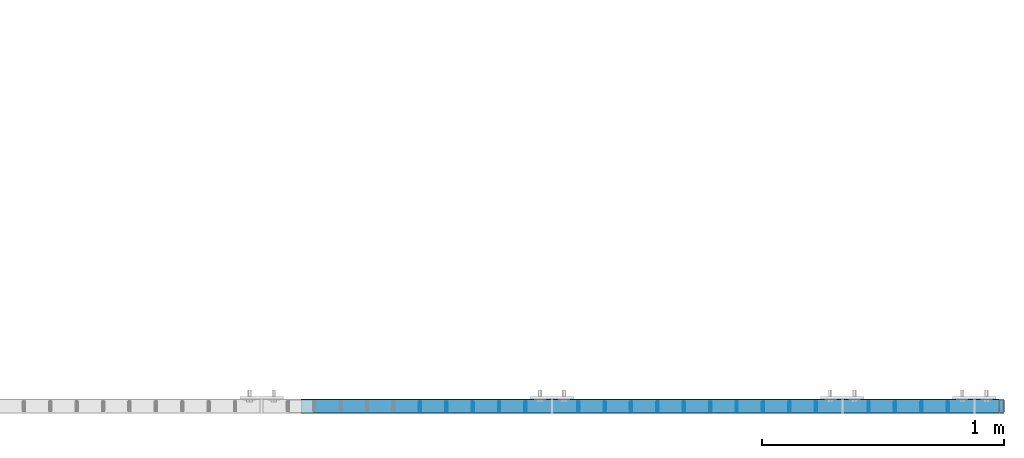
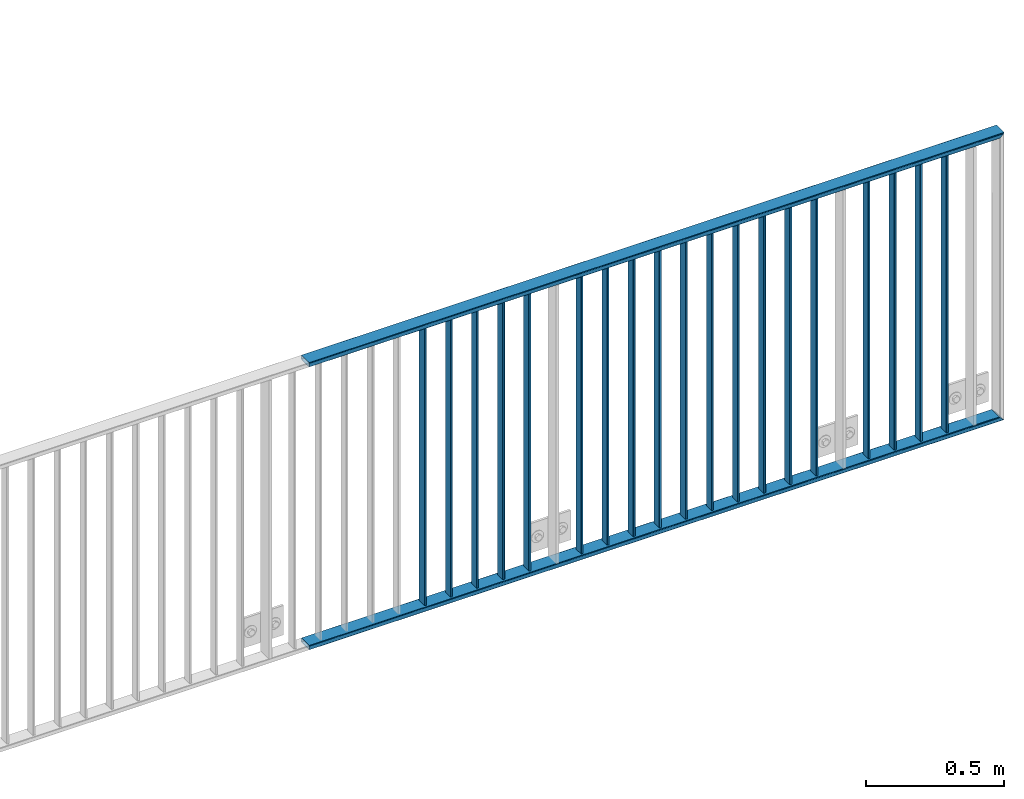
# One storey, part 31 of 156: 21 beams, 1 element without a shape of its own.
"""IFC2X3 building model written with IfcOpenShell, lengths in millimetres."""

from ifc_helpers import new_model, si_unit, frame, origin_with_axes, origin_2d_with_axis, place, context, subcontext, project, spatial, hollow_rectangle, extrude, clip, halfspace, material, type_object, element, aggregate, save


model = new_model("IFC2X3")

# Units and contexts
model_context = context("Model", 3, precision=1e-05, world=origin_with_axes())
body_context = subcontext(model_context, "Body", "Model", "MODEL_VIEW")
ifc_project = project(units=[si_unit("LENGTHUNIT", "METRE", prefix="MILLI"), si_unit("AREAUNIT", "SQUARE_METRE"), si_unit("VOLUMEUNIT", "CUBIC_METRE"), si_unit("MASSUNIT", "GRAM", prefix="KILO"), si_unit("TIMEUNIT", "SECOND"), si_unit("PLANEANGLEUNIT", "RADIAN"), si_unit("SOLIDANGLEUNIT", "STERADIAN"), si_unit("THERMODYNAMICTEMPERATUREUNIT", "DEGREE_CELSIUS"), si_unit("LUMINOUSINTENSITYUNIT", "LUMEN")], contexts=[model_context])

# Site, building, storey
site_placement = place(None, origin_with_axes())
site = spatial("IfcSite", under=ifc_project, at=site_placement, CompositionType="ELEMENT")
building_placement = place(site_placement, origin_with_axes())
building = spatial("IfcBuilding", under=site, at=building_placement, Name="Undefined", CompositionType="ELEMENT")
storey_placement = place(building_placement, origin_with_axes())
storey = spatial("IfcBuildingStorey", under=building, at=storey_placement, Name="Undefined", CompositionType="ELEMENT", Elevation=0.0)

# Assembly, beams
assembly_placement = place(storey_placement, origin_with_axes())
assembly = element("IfcElementAssembly", 1, at=assembly_placement, inside=storey, AssemblyPlace="NOTDEFINED", PredefinedType="RIGID_FRAME")
ifc_material = material(Name="STEEL/S235JR")
beam_type_1 = type_object("IfcBeamType", Name="K60/20/2", PredefinedType="NOTDEFINED")
beam_1_placement = place(assembly_placement, frame((46763.0399999997, 8480.00209045412, 2740.0), z_axis=(0.0, 1.0, 0.0), x_axis=(1.0, 0.0, 0.0)))
beam_1 = element("IfcBeam", 2, at=beam_1_placement, type_object=beam_type_1, material=ifc_material, ObjectType="K60/20/2", context=body_context, shape_type="Clipping", body=[
    clip(extrude(hollow_rectangle(XDim=20.0, YDim=60.0, WallThickness=2.0, InnerFilletRadius=2.0, OuterFilletRadius=4.0, at=origin_2d_with_axis()), frame((2905.05999999928, 0.0, 0.0), z_axis=(-1.0, 0.0, 0.0), x_axis=(0.0, -1.0, 0.0)), (0.0, 0.0, 1.0), 2905.06), halfspace(frame((2904.95999999928, 10.0, 7.25158861314412e-06), z_axis=(-0.707106781186548, 0.707106781186548, 0.0), x_axis=(0.0, 0.0, 1.0)), True)),
])
beam_2_placement = place(assembly_placement, frame((46763.0399999997, 8479.98209043043, 3990.0), z_axis=(0.0, 1.0, 0.0), x_axis=(1.0, 0.0, 0.0)))
beam_2 = element("IfcBeam", 3, at=beam_2_placement, type_object=beam_type_1, material=ifc_material, ObjectType="K60/20/2", context=body_context, shape_type="Clipping", body=[
    clip(extrude(hollow_rectangle(XDim=20.0, YDim=60.0, WallThickness=2.0, InnerFilletRadius=2.0, OuterFilletRadius=4.0, at=origin_2d_with_axis()), frame((2905.05999999928, 0.0, 0.0), z_axis=(-1.0, 0.0, 0.0), x_axis=(0.0, -1.0, 0.0)), (0.0, 0.0, 1.0), 2905.06), halfspace(frame((2884.95999999927, 10.0, 0.0200072752795677), z_axis=(-0.707106781186548, -0.707106781186548, 0.0), x_axis=(0.0, 0.0, 1.0)), True)),
])
beam_type_2 = type_object("IfcBeamType", Name="K40/10/1.5", PredefinedType="NOTDEFINED")
beam_3_placement = place(assembly_placement, frame((49436.359999999, 8480.00209765299, 3980.00000000003), z_axis=(0.0, 1.0, 0.0), x_axis=(0.0, 0.0, -1.0)))
beam_3 = element("IfcBeam", 4, at=beam_3_placement, type_object=beam_type_2, material=ifc_material, ObjectType="K40/10/1.5", context=body_context, shape_type="Clipping", body=[
    clip(extrude(hollow_rectangle(XDim=10.0, YDim=40.0, WallThickness=1.5, InnerFilletRadius=1.5, OuterFilletRadius=3.0, at=origin_2d_with_axis()), frame((1230.0, 0.0, 0.0), z_axis=(-1.0, 0.0, 0.0), x_axis=(0.0, -1.0, 0.0)), (0.0, 0.0, 1.0), 1230.0), halfspace(frame((-6.99999999997453, -4.34248751950508, 47.3810900558092), z_axis=(-1.0, 0.0, 0.0), x_axis=(0.0, 0.7683548141934, -0.640024124159258)), False)),
])
beam_4_placement = place(assembly_placement, frame((49327.269999999, 8480.00209765299, 3980.00000000003), z_axis=(0.0, 1.0, 0.0), x_axis=(0.0, 0.0, -1.0)))
beam_4 = element("IfcBeam", 5, at=beam_4_placement, type_object=beam_type_2, material=ifc_material, ObjectType="K40/10/1.5", context=body_context, shape_type="Clipping", body=[
    clip(extrude(hollow_rectangle(XDim=10.0, YDim=40.0, WallThickness=1.5, InnerFilletRadius=1.5, OuterFilletRadius=3.0, at=origin_2d_with_axis()), frame((1230.0, 0.0, 0.0), z_axis=(-1.0, 0.0, 0.0), x_axis=(0.0, -1.0, 0.0)), (0.0, 0.0, 1.0), 1230.0), halfspace(frame((-6.99999999997453, -4.34248751950508, 47.3810900558092), z_axis=(-1.0, 0.0, 0.0), x_axis=(0.0, 0.7683548141934, -0.640024124159258)), False)),
])
beam_5_placement = place(assembly_placement, frame((49218.179999999, 8480.00209765299, 3980.00000000003), z_axis=(0.0, 1.0, 0.0), x_axis=(0.0, 0.0, -1.0)))
beam_5 = element("IfcBeam", 6, at=beam_5_placement, type_object=beam_type_2, material=ifc_material, ObjectType="K40/10/1.5", context=body_context, shape_type="Clipping", body=[
    clip(extrude(hollow_rectangle(XDim=10.0, YDim=40.0, WallThickness=1.5, InnerFilletRadius=1.5, OuterFilletRadius=3.0, at=origin_2d_with_axis()), frame((1230.0, 0.0, 0.0), z_axis=(-1.0, 0.0, 0.0), x_axis=(0.0, -1.0, 0.0)), (0.0, 0.0, 1.0), 1230.0), halfspace(frame((-6.99999999997453, -4.34248751950508, 47.3810900558092), z_axis=(-1.0, 0.0, 0.0), x_axis=(0.0, 0.7683548141934, -0.640024124159258)), False)),
])
beam_6_placement = place(assembly_placement, frame((49109.089999999, 8480.00209765299, 3980.00000000003), z_axis=(0.0, 1.0, 0.0), x_axis=(0.0, 0.0, -1.0)))
beam_6 = element("IfcBeam", 7, at=beam_6_placement, type_object=beam_type_2, material=ifc_material, ObjectType="K40/10/1.5", context=body_context, shape_type="Clipping", body=[
    clip(extrude(hollow_rectangle(XDim=10.0, YDim=40.0, WallThickness=1.5, InnerFilletRadius=1.5, OuterFilletRadius=3.0, at=origin_2d_with_axis()), frame((1230.0, 0.0, 0.0), z_axis=(-1.0, 0.0, 0.0), x_axis=(0.0, -1.0, 0.0)), (0.0, 0.0, 1.0), 1230.0), halfspace(frame((-6.99999999997453, -4.34248751950508, 47.3810900558092), z_axis=(-1.0, 0.0, 0.0), x_axis=(0.0, 0.7683548141934, -0.640024124159258)), False)),
])
beam_7_placement = place(assembly_placement, frame((48890.899999999, 8480.00209765299, 3980.00000000003), z_axis=(0.0, 1.0, 0.0), x_axis=(0.0, 0.0, -1.0)))
beam_7 = element("IfcBeam", 8, at=beam_7_placement, type_object=beam_type_2, material=ifc_material, ObjectType="K40/10/1.5", context=body_context, shape_type="Clipping", body=[
    clip(extrude(hollow_rectangle(XDim=10.0, YDim=40.0, WallThickness=1.5, InnerFilletRadius=1.5, OuterFilletRadius=3.0, at=origin_2d_with_axis()), frame((1230.0, 0.0, 0.0), z_axis=(-1.0, 0.0, 0.0), x_axis=(0.0, -1.0, 0.0)), (0.0, 0.0, 1.0), 1230.0), halfspace(frame((-6.99999999997453, -4.34248751950508, 47.3810900558092), z_axis=(-1.0, 0.0, 0.0), x_axis=(0.0, 0.7683548141934, -0.640024124159258)), False)),
])
beam_8_placement = place(assembly_placement, frame((48781.809999999, 8480.00209765299, 3980.00000000003), z_axis=(0.0, 1.0, 0.0), x_axis=(0.0, 0.0, -1.0)))
beam_8 = element("IfcBeam", 9, at=beam_8_placement, type_object=beam_type_2, material=ifc_material, ObjectType="K40/10/1.5", context=body_context, shape_type="Clipping", body=[
    clip(extrude(hollow_rectangle(XDim=10.0, YDim=40.0, WallThickness=1.5, InnerFilletRadius=1.5, OuterFilletRadius=3.0, at=origin_2d_with_axis()), frame((1230.0, 0.0, 0.0), z_axis=(-1.0, 0.0, 0.0), x_axis=(0.0, -1.0, 0.0)), (0.0, 0.0, 1.0), 1230.0), halfspace(frame((-6.99999999997453, -4.34248751950508, 47.3810900558092), z_axis=(-1.0, 0.0, 0.0), x_axis=(0.0, 0.7683548141934, -0.640024124159258)), False)),
])
beam_9_placement = place(assembly_placement, frame((48672.719999999, 8480.00209765299, 3980.00000000003), z_axis=(0.0, 1.0, 0.0), x_axis=(0.0, 0.0, -1.0)))
beam_9 = element("IfcBeam", 10, at=beam_9_placement, type_object=beam_type_2, material=ifc_material, ObjectType="K40/10/1.5", context=body_context, shape_type="Clipping", body=[
    clip(extrude(hollow_rectangle(XDim=10.0, YDim=40.0, WallThickness=1.5, InnerFilletRadius=1.5, OuterFilletRadius=3.0, at=origin_2d_with_axis()), frame((1230.0, 0.0, 0.0), z_axis=(-1.0, 0.0, 0.0), x_axis=(0.0, -1.0, 0.0)), (0.0, 0.0, 1.0), 1230.0), halfspace(frame((-6.99999999997453, -4.34248751950508, 47.3810900558092), z_axis=(-1.0, 0.0, 0.0), x_axis=(0.0, 0.7683548141934, -0.640024124159258)), False)),
])
beam_10_placement = place(assembly_placement, frame((48563.629999999, 8480.00209765299, 3980.00000000003), z_axis=(0.0, 1.0, 0.0), x_axis=(0.0, 0.0, -1.0)))
beam_10 = element("IfcBeam", 11, at=beam_10_placement, type_object=beam_type_2, material=ifc_material, ObjectType="K40/10/1.5", context=body_context, shape_type="Clipping", body=[
    clip(extrude(hollow_rectangle(XDim=10.0, YDim=40.0, WallThickness=1.5, InnerFilletRadius=1.5, OuterFilletRadius=3.0, at=origin_2d_with_axis()), frame((1230.0, 0.0, 0.0), z_axis=(-1.0, 0.0, 0.0), x_axis=(0.0, -1.0, 0.0)), (0.0, 0.0, 1.0), 1230.0), halfspace(frame((-6.99999999997453, -4.34248751950508, 47.3810900558092), z_axis=(-1.0, 0.0, 0.0), x_axis=(0.0, 0.7683548141934, -0.640024124159258)), False)),
])
beam_11_placement = place(assembly_placement, frame((48454.539999999, 8480.00209765299, 3980.00000000003), z_axis=(0.0, 1.0, 0.0), x_axis=(0.0, 0.0, -1.0)))
beam_11 = element("IfcBeam", 12, at=beam_11_placement, type_object=beam_type_2, material=ifc_material, ObjectType="K40/10/1.5", context=body_context, shape_type="Clipping", body=[
    clip(extrude(hollow_rectangle(XDim=10.0, YDim=40.0, WallThickness=1.5, InnerFilletRadius=1.5, OuterFilletRadius=3.0, at=origin_2d_with_axis()), frame((1230.0, 0.0, 0.0), z_axis=(-1.0, 0.0, 0.0), x_axis=(0.0, -1.0, 0.0)), (0.0, 0.0, 1.0), 1230.0), halfspace(frame((-6.99999999997453, -4.34248751950508, 47.3810900558092), z_axis=(-1.0, 0.0, 0.0), x_axis=(0.0, 0.7683548141934, -0.640024124159258)), False)),
])
beam_12_placement = place(assembly_placement, frame((48345.449999999, 8480.00209765299, 3980.00000000003), z_axis=(0.0, 1.0, 0.0), x_axis=(0.0, 0.0, -1.0)))
beam_12 = element("IfcBeam", 13, at=beam_12_placement, type_object=beam_type_2, material=ifc_material, ObjectType="K40/10/1.5", context=body_context, shape_type="Clipping", body=[
    clip(extrude(hollow_rectangle(XDim=10.0, YDim=40.0, WallThickness=1.5, InnerFilletRadius=1.5, OuterFilletRadius=3.0, at=origin_2d_with_axis()), frame((1230.0, 0.0, 0.0), z_axis=(-1.0, 0.0, 0.0), x_axis=(0.0, -1.0, 0.0)), (0.0, 0.0, 1.0), 1230.0), halfspace(frame((-6.99999999997453, -4.34248751950508, 47.3810900558092), z_axis=(-1.0, 0.0, 0.0), x_axis=(0.0, 0.7683548141934, -0.640024124159258)), False)),
])
beam_13_placement = place(assembly_placement, frame((48236.359999999, 8480.00209765299, 3980.00000000003), z_axis=(0.0, 1.0, 0.0), x_axis=(0.0, 0.0, -1.0)))
beam_13 = element("IfcBeam", 14, at=beam_13_placement, type_object=beam_type_2, material=ifc_material, ObjectType="K40/10/1.5", context=body_context, shape_type="Clipping", body=[
    clip(extrude(hollow_rectangle(XDim=10.0, YDim=40.0, WallThickness=1.5, InnerFilletRadius=1.5, OuterFilletRadius=3.0, at=origin_2d_with_axis()), frame((1230.0, 0.0, 0.0), z_axis=(-1.0, 0.0, 0.0), x_axis=(0.0, -1.0, 0.0)), (0.0, 0.0, 1.0), 1230.0), halfspace(frame((-6.99999999997453, -4.34248751950508, 47.3810900558092), z_axis=(-1.0, 0.0, 0.0), x_axis=(0.0, 0.7683548141934, -0.640024124159258)), False)),
])
beam_14_placement = place(assembly_placement, frame((48127.269999999, 8480.00209765299, 3980.00000000003), z_axis=(0.0, 1.0, 0.0), x_axis=(0.0, 0.0, -1.0)))
beam_14 = element("IfcBeam", 15, at=beam_14_placement, type_object=beam_type_2, material=ifc_material, ObjectType="K40/10/1.5", context=body_context, shape_type="Clipping", body=[
    clip(extrude(hollow_rectangle(XDim=10.0, YDim=40.0, WallThickness=1.5, InnerFilletRadius=1.5, OuterFilletRadius=3.0, at=origin_2d_with_axis()), frame((1230.0, 0.0, 0.0), z_axis=(-1.0, 0.0, 0.0), x_axis=(0.0, -1.0, 0.0)), (0.0, 0.0, 1.0), 1230.0), halfspace(frame((-6.99999999997453, -4.34248751950508, 47.3810900558092), z_axis=(-1.0, 0.0, 0.0), x_axis=(0.0, 0.7683548141934, -0.640024124159258)), False)),
])
beam_15_placement = place(assembly_placement, frame((48018.179999999, 8480.00209765299, 3980.00000000003), z_axis=(0.0, 1.0, 0.0), x_axis=(0.0, 0.0, -1.0)))
beam_15 = element("IfcBeam", 16, at=beam_15_placement, type_object=beam_type_2, material=ifc_material, ObjectType="K40/10/1.5", context=body_context, shape_type="Clipping", body=[
    clip(extrude(hollow_rectangle(XDim=10.0, YDim=40.0, WallThickness=1.5, InnerFilletRadius=1.5, OuterFilletRadius=3.0, at=origin_2d_with_axis()), frame((1230.0, 0.0, 0.0), z_axis=(-1.0, 0.0, 0.0), x_axis=(0.0, -1.0, 0.0)), (0.0, 0.0, 1.0), 1230.0), halfspace(frame((-6.99999999997453, -4.34248751950508, 47.3810900558092), z_axis=(-1.0, 0.0, 0.0), x_axis=(0.0, 0.7683548141934, -0.640024124159258)), False)),
])
beam_16_placement = place(assembly_placement, frame((47909.089999999, 8480.00209765299, 3980.00000000003), z_axis=(0.0, 1.0, 0.0), x_axis=(0.0, 0.0, -1.0)))
beam_16 = element("IfcBeam", 17, at=beam_16_placement, type_object=beam_type_2, material=ifc_material, ObjectType="K40/10/1.5", context=body_context, shape_type="Clipping", body=[
    clip(extrude(hollow_rectangle(XDim=10.0, YDim=40.0, WallThickness=1.5, InnerFilletRadius=1.5, OuterFilletRadius=3.0, at=origin_2d_with_axis()), frame((1230.0, 0.0, 0.0), z_axis=(-1.0, 0.0, 0.0), x_axis=(0.0, -1.0, 0.0)), (0.0, 0.0, 1.0), 1230.0), halfspace(frame((-6.99999999997453, -4.34248751950508, 47.3810900558092), z_axis=(-1.0, 0.0, 0.0), x_axis=(0.0, 0.7683548141934, -0.640024124159258)), False)),
])
beam_17_placement = place(assembly_placement, frame((47690.899999999, 8480.00209765299, 3980.00000000003), z_axis=(0.0, 1.0, 0.0), x_axis=(0.0, 0.0, -1.0)))
beam_17 = element("IfcBeam", 18, at=beam_17_placement, type_object=beam_type_2, material=ifc_material, ObjectType="K40/10/1.5", context=body_context, shape_type="Clipping", body=[
    clip(extrude(hollow_rectangle(XDim=10.0, YDim=40.0, WallThickness=1.5, InnerFilletRadius=1.5, OuterFilletRadius=3.0, at=origin_2d_with_axis()), frame((1230.0, 0.0, 0.0), z_axis=(-1.0, 0.0, 0.0), x_axis=(0.0, -1.0, 0.0)), (0.0, 0.0, 1.0), 1230.0), halfspace(frame((-6.99999999997453, -4.34248751950508, 47.3810900558092), z_axis=(-1.0, 0.0, 0.0), x_axis=(0.0, 0.7683548141934, -0.640024124159258)), False)),
])
beam_18_placement = place(assembly_placement, frame((47581.809999999, 8480.00209765299, 3980.00000000003), z_axis=(0.0, 1.0, 0.0), x_axis=(0.0, 0.0, -1.0)))
beam_18 = element("IfcBeam", 19, at=beam_18_placement, type_object=beam_type_2, material=ifc_material, ObjectType="K40/10/1.5", context=body_context, shape_type="Clipping", body=[
    clip(extrude(hollow_rectangle(XDim=10.0, YDim=40.0, WallThickness=1.5, InnerFilletRadius=1.5, OuterFilletRadius=3.0, at=origin_2d_with_axis()), frame((1230.0, 0.0, 0.0), z_axis=(-1.0, 0.0, 0.0), x_axis=(0.0, -1.0, 0.0)), (0.0, 0.0, 1.0), 1230.0), halfspace(frame((-6.99999999997453, -4.34248751950508, 47.3810900558092), z_axis=(-1.0, 0.0, 0.0), x_axis=(0.0, 0.7683548141934, -0.640024124159258)), False)),
])
beam_19_placement = place(assembly_placement, frame((47472.719999999, 8480.00209765299, 3980.00000000003), z_axis=(0.0, 1.0, 0.0), x_axis=(0.0, 0.0, -1.0)))
beam_19 = element("IfcBeam", 20, at=beam_19_placement, type_object=beam_type_2, material=ifc_material, ObjectType="K40/10/1.5", context=body_context, shape_type="Clipping", body=[
    clip(extrude(hollow_rectangle(XDim=10.0, YDim=40.0, WallThickness=1.5, InnerFilletRadius=1.5, OuterFilletRadius=3.0, at=origin_2d_with_axis()), frame((1230.0, 0.0, 0.0), z_axis=(-1.0, 0.0, 0.0), x_axis=(0.0, -1.0, 0.0)), (0.0, 0.0, 1.0), 1230.0), halfspace(frame((-6.99999999997453, -4.34248751950508, 47.3810900558092), z_axis=(-1.0, 0.0, 0.0), x_axis=(0.0, 0.7683548141934, -0.640024124159258)), False)),
])
beam_20_placement = place(assembly_placement, frame((47363.629999999, 8480.00209765299, 3980.00000000003), z_axis=(0.0, 1.0, 0.0), x_axis=(0.0, 0.0, -1.0)))
beam_20 = element("IfcBeam", 21, at=beam_20_placement, type_object=beam_type_2, material=ifc_material, ObjectType="K40/10/1.5", context=body_context, shape_type="Clipping", body=[
    clip(extrude(hollow_rectangle(XDim=10.0, YDim=40.0, WallThickness=1.5, InnerFilletRadius=1.5, OuterFilletRadius=3.0, at=origin_2d_with_axis()), frame((1230.0, 0.0, 0.0), z_axis=(-1.0, 0.0, 0.0), x_axis=(0.0, -1.0, 0.0)), (0.0, 0.0, 1.0), 1230.0), halfspace(frame((-6.99999999997453, -4.34248751950508, 47.3810900558092), z_axis=(-1.0, 0.0, 0.0), x_axis=(0.0, 0.7683548141934, -0.640024124159258)), False)),
])
beam_21_placement = place(assembly_placement, frame((47254.539999999, 8480.00209765299, 3980.00000000003), z_axis=(0.0, 1.0, 0.0), x_axis=(0.0, 0.0, -1.0)))
beam_21 = element("IfcBeam", 22, at=beam_21_placement, type_object=beam_type_2, material=ifc_material, ObjectType="K40/10/1.5", context=body_context, shape_type="Clipping", body=[
    clip(extrude(hollow_rectangle(XDim=10.0, YDim=40.0, WallThickness=1.5, InnerFilletRadius=1.5, OuterFilletRadius=3.0, at=origin_2d_with_axis()), frame((1230.0, 0.0, 0.0), z_axis=(-1.0, 0.0, 0.0), x_axis=(0.0, -1.0, 0.0)), (0.0, 0.0, 1.0), 1230.0), halfspace(frame((-6.99999999997453, -4.34248751950508, 47.3810900558092), z_axis=(-1.0, 0.0, 0.0), x_axis=(0.0, 0.7683548141934, -0.640024124159258)), False)),
])
aggregate(assembly, [beam_1, beam_2, beam_3, beam_4, beam_5, beam_6, beam_7, beam_8, beam_9, beam_10, beam_11, beam_12, beam_13, beam_14, beam_15, beam_16, beam_17, beam_18, beam_19, beam_20, beam_21])

save(model, "model.ifc")
